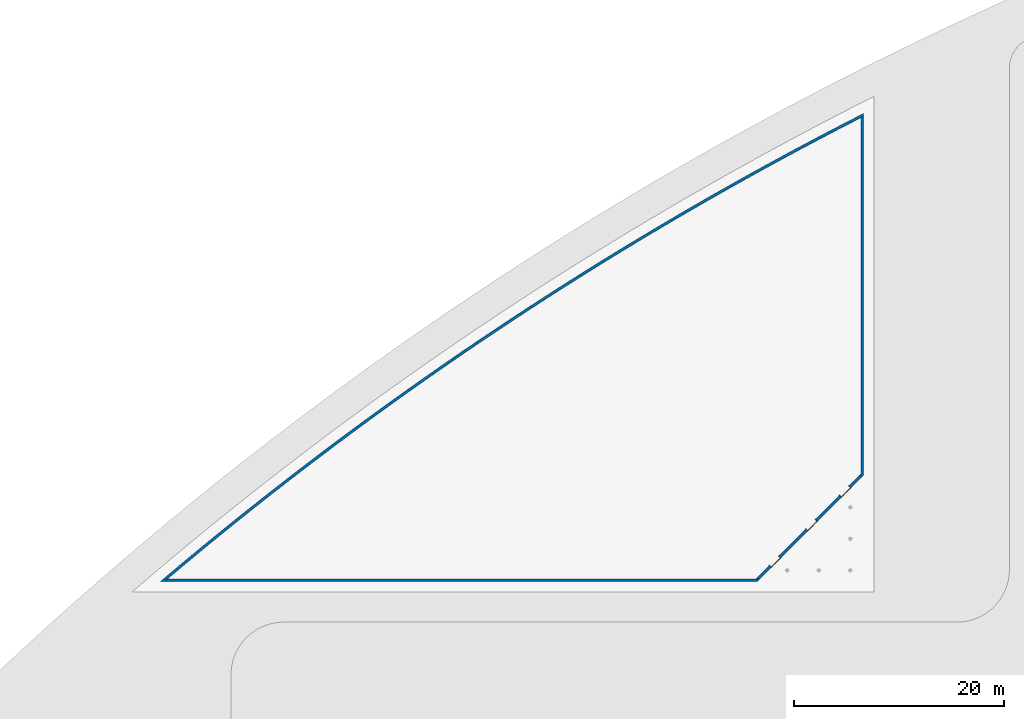
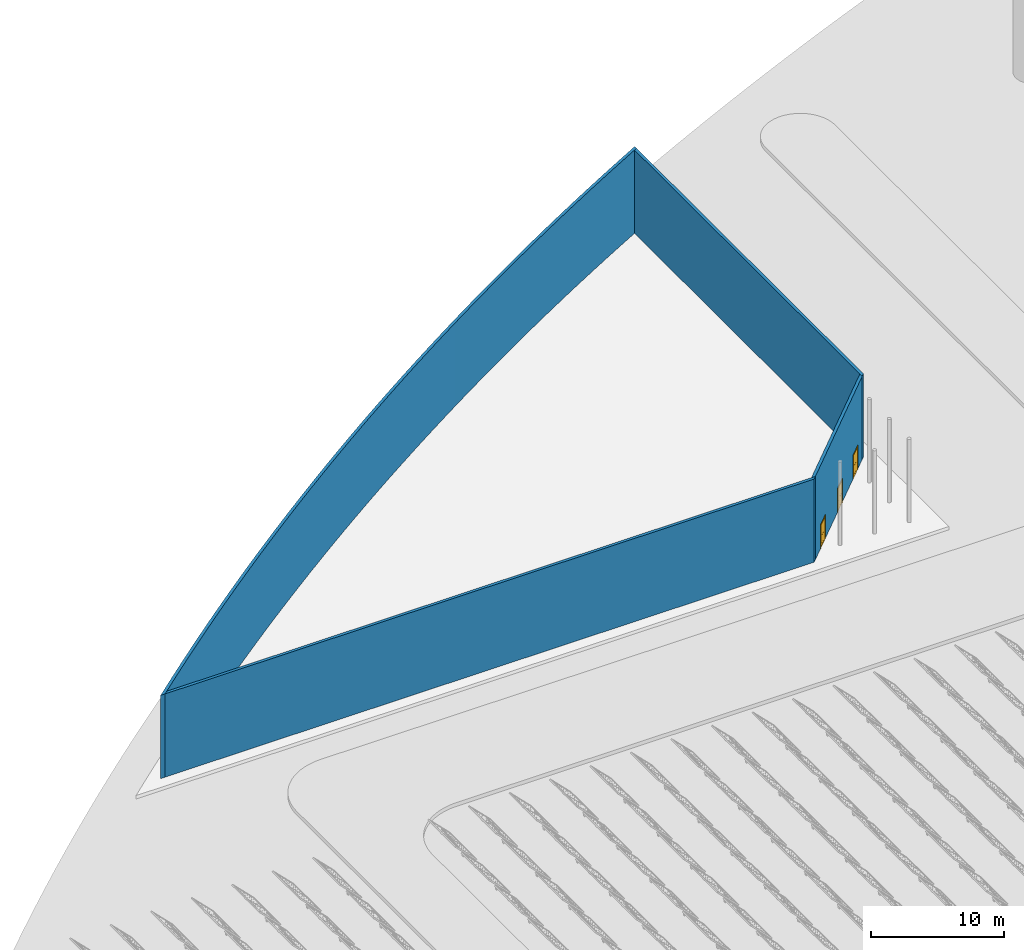
# One storey, part 12 of 39: 4 walls, 3 doors, 3 openings.
"""IFC2X3 building model written with IfcOpenShell, lengths in millimetres."""

import ifcopenshell
import ifcopenshell.guid

model = None  # the IFC model being written
_history = None  # IfcOwnerHistory: only IFC2X3 demands one
_inside = {}  # id of a spatial element -> (the spatial element, [elements in it])
_under = {}  # id of a project, library or spatial element -> (it, [spatial elements below it])
_declared = {}  # id of a project -> (the project, [libraries it declares])
_typed = {}  # id of a type object -> (the type object, [elements of that type])
_made_of = {}  # id of a material, layer set ... -> (it, [elements and type objects made of it])


def new_model(schema):
    """Start an empty IFC model of exactly this schema.

    Asked for "IFC4X3", IfcOpenShell would pick the latest addendum, in which some entities
    have other attributes; the version numbers below select the first issue.
    IFC2X3 requires an IfcOwnerHistory on every rooted entity: one is made here for all.
    """
    global model, _history
    if schema == "IFC4X3":
        model = ifcopenshell.file(schema_version=(4, 3, 0, 0))
    else:
        model = ifcopenshell.file(schema=schema)
    _inside.clear()
    _under.clear()
    _declared.clear()
    _typed.clear()
    _made_of.clear()
    _history = None
    if model.schema == "IFC2X3":
        org = make("IfcOrganization", Name="unknown")
        user = make(
            "IfcPersonAndOrganization",
            ThePerson=make("IfcPerson", FamilyName="unknown"),
            TheOrganization=org,
        )
        app = make(
            "IfcApplication",
            ApplicationDeveloper=org,
            Version="unknown",
            ApplicationFullName="unknown",
            ApplicationIdentifier="unknown",
        )
        _history = make(
            "IfcOwnerHistory",
            OwningUser=user,
            OwningApplication=app,
            ChangeAction="ADDED",
            CreationDate=0,
        )
    return model


def make(cls, **values):
    """One entity of the class cls with the attributes given. An attribute that is None is left unset."""
    return model.create_entity(
        cls, **{name: value for name, value in values.items() if value is not None}
    )


def entity(cls, *values):
    """Any entity or typed value of the class cls, its attributes in the order of the schema. None: left unset."""
    e = model.create_entity(cls)
    for i, value in enumerate(values):
        if value is not None:
            e[i] = value
    return e


def rooted(cls, **values):
    """An entity with a GlobalId (a new one), such as an element, a storey or a relation."""
    return make(cls, GlobalId=ifcopenshell.guid.new(), OwnerHistory=_history, **values)


def si_unit(unit_type, name, prefix=None):
    """IfcSIUnit, for example si_unit("LENGTHUNIT", "METRE", prefix="MILLI")."""
    return make("IfcSIUnit", UnitType=unit_type, Prefix=prefix, Name=name)


def converted_unit(unit_type, name, factor, base, dimensions=None, offset=None):
    """IfcConversionBasedUnit, such as the inch: factor (a typed value) times the base unit."""
    return make(
        "IfcConversionBasedUnit"
        if offset is None
        else "IfcConversionBasedUnitWithOffset",
        ConversionOffset=offset,
        Dimensions=None
        if dimensions is None
        else entity("IfcDimensionalExponents", *dimensions),
        UnitType=unit_type,
        Name=name,
        ConversionFactor=make(
            "IfcMeasureWithUnit", ValueComponent=factor, UnitComponent=base
        ),
    )


def derived_unit(unit_type, elements):
    """IfcDerivedUnit: a product of units, each with its exponent."""
    return make(
        "IfcDerivedUnit",
        Elements=[
            make("IfcDerivedUnitElement", Unit=unit, Exponent=power)
            for unit, power in elements
        ],
        UnitType=unit_type,
    )


def assignment(units):
    """IfcUnitAssignment: the units of a project."""
    return None if units is None else make("IfcUnitAssignment", Units=units)


def point(xyz):
    """IfcCartesianPoint."""
    return None if xyz is None else make("IfcCartesianPoint", Coordinates=xyz)


def direction(xyz):
    """IfcDirection."""
    return None if xyz is None else make("IfcDirection", DirectionRatios=xyz)


def frame(location, z_axis=None, x_axis=None):
    """IfcAxis2Placement3D, a coordinate frame: its origin and axes. An axis left out is left unset."""
    return make(
        "IfcAxis2Placement3D",
        Location=point(location),
        Axis=direction(z_axis),
        RefDirection=direction(x_axis),
    )


def frame_2d(location, x_axis=None):
    """IfcAxis2Placement2D, a coordinate frame in the plane: its origin and x axis."""
    return make(
        "IfcAxis2Placement2D", Location=point(location), RefDirection=direction(x_axis)
    )


def origin():
    """The frame at (0, 0, 0) with its axes left unset."""
    return frame((0.0, 0.0, 0.0))


def origin_2d_with_axis():
    """The frame at (0, 0) in the plane with the x axis (1, 0) written out."""
    return frame_2d((0.0, 0.0), x_axis=(1.0, 0.0))


def place(relative_to, where):
    """IfcLocalPlacement: puts the frame where relative to a parent placement (None: the world)."""
    return make(
        "IfcLocalPlacement", PlacementRelTo=relative_to, RelativePlacement=where
    )


def context(
    kind, dimensions, precision=None, world=None, true_north=None, identifier=None
):
    """IfcGeometricRepresentationContext, for example the 3D "Model" context."""
    return make(
        "IfcGeometricRepresentationContext",
        ContextIdentifier=identifier,
        ContextType=kind,
        CoordinateSpaceDimension=dimensions,
        Precision=precision,
        WorldCoordinateSystem=world,
        TrueNorth=true_north,
    )


def subcontext(parent, identifier, kind, view, scale=None):
    """IfcGeometricRepresentationSubContext, for example "Body" below "Model"."""
    return make(
        "IfcGeometricRepresentationSubContext",
        ContextIdentifier=identifier,
        ContextType=kind,
        ParentContext=parent,
        TargetScale=scale,
        TargetView=view,
    )


def project(units=None, contexts=None):
    """IfcProject with its units and contexts."""
    return rooted(
        "IfcProject",
        Name="project",
        RepresentationContexts=contexts,
        UnitsInContext=assignment(units),
    )


def spatial(cls, under=None, at=None, **own):
    """A site, building, storey or space (cls), placed at a placement, below another one or the project."""
    s = rooted(cls, ObjectPlacement=at, **own)
    if under is not None:
        _under.setdefault(under.id(), (under, []))[1].append(s)
    return s


def polyline(points):
    """IfcPolyline through the points."""
    return make("IfcPolyline", Points=[point(p) for p in points])


def circle_curve(where, radius):
    """IfcCircle in the frame where."""
    return make("IfcCircle", Position=where, Radius=radius)


def parameter(value):
    """IfcParameterValue: where a trimmed curve begins or ends, as a parameter of its basis curve."""
    return model.create_entity("IfcParameterValue", value)


def trimmed(basis, trim1, trim2, sense, master):
    """IfcTrimmedCurve: the piece of a basis curve between two trims."""
    return make(
        "IfcTrimmedCurve",
        BasisCurve=basis,
        Trim1=trim1,
        Trim2=trim2,
        SenseAgreement=sense,
        MasterRepresentation=master,
    )


def segment(curve, same_sense, transition):
    """IfcCompositeCurveSegment."""
    return make(
        "IfcCompositeCurveSegment",
        Transition=transition,
        SameSense=same_sense,
        ParentCurve=curve,
    )


def composite_curve(segments, self_intersect=None):
    """IfcCompositeCurve: segments joined end to end."""
    return make("IfcCompositeCurve", Segments=segments, SelfIntersect=self_intersect)


def profile(cls, at=None, kind="AREA", **sizes):
    """A parametric profile (cls). Its sizes go by their IFC names, for example OverallWidth=200.0."""
    return make(cls, ProfileType=kind, Position=at, **sizes)


def rectangle(**sizes):
    """IfcRectangleProfileDef."""
    return profile("IfcRectangleProfileDef", **sizes)


def outline(outer, holes=None, kind="AREA"):
    """IfcArbitraryClosedProfileDef: a profile drawn as a closed curve; with holes, ...WithVoids."""
    if holes is None:
        return make("IfcArbitraryClosedProfileDef", ProfileType=kind, OuterCurve=outer)
    return make(
        "IfcArbitraryProfileDefWithVoids",
        ProfileType=kind,
        OuterCurve=outer,
        InnerCurves=holes,
    )


def extrude(swept, where, along, depth):
    """IfcExtrudedAreaSolid: the profile swept, set in the frame where, extruded along a direction by depth."""
    return make(
        "IfcExtrudedAreaSolid",
        SweptArea=swept,
        Position=where,
        ExtrudedDirection=direction(along),
        Depth=depth,
    )


def shape(context_of_items, identifier, shape_type, items):
    """IfcShapeRepresentation: the items that make up one representation, for example the "Body"."""
    return make(
        "IfcShapeRepresentation",
        ContextOfItems=context_of_items,
        RepresentationIdentifier=identifier,
        RepresentationType=shape_type,
        Items=items,
    )


def source(mapping_origin, context_of_items, identifier, shape_type, items):
    """IfcRepresentationMap: a shape defined once, which mapped items show again and again."""
    return make(
        "IfcRepresentationMap",
        MappingOrigin=mapping_origin,
        MappedRepresentation=shape(context_of_items, identifier, shape_type, items),
    )


def transform(
    local_origin,
    x_axis=None,
    y_axis=None,
    z_axis=None,
    scale=None,
    scale2=None,
    scale3=None,
    uniform=True,
):
    """IfcCartesianTransformationOperator3D, or its non-uniform kind. x_axis, y_axis, z_axis: its Axis1, 2, 3."""
    if uniform:
        return make(
            "IfcCartesianTransformationOperator3D",
            Axis1=direction(x_axis),
            Axis2=direction(y_axis),
            LocalOrigin=point(local_origin),
            Scale=scale,
            Axis3=direction(z_axis),
        )
    return make(
        "IfcCartesianTransformationOperator3DnonUniform",
        Axis1=direction(x_axis),
        Axis2=direction(y_axis),
        LocalOrigin=point(local_origin),
        Scale=scale,
        Axis3=direction(z_axis),
        Scale2=scale2,
        Scale3=scale3,
    )


def mapped(mapping_source, mapping_target):
    """IfcMappedItem: shows the shape of a source again, moved by a transform."""
    return make(
        "IfcMappedItem", MappingSource=mapping_source, MappingTarget=mapping_target
    )


def material(Name=None, Category=None):
    """IfcMaterial."""
    return make("IfcMaterial", Name=Name, Category=Category)


def material_list(materials):
    """IfcMaterialList."""
    return make("IfcMaterialList", Materials=materials)


def layer(
    of_material, thickness, ventilated=None, Name=None, Category=None, Priority=None
):
    """IfcMaterialLayer: one layer of a wall or slab, of a material (None: an air gap)."""
    return make(
        "IfcMaterialLayer",
        Material=of_material,
        LayerThickness=thickness,
        IsVentilated=ventilated,
        Name=Name,
        Category=Category,
        Priority=Priority,
    )


def layer_set(layers, Name=None):
    """IfcMaterialLayerSet."""
    return make("IfcMaterialLayerSet", MaterialLayers=layers, LayerSetName=Name)


def layer_usage(for_layer_set, set_direction, sense, offset, extent=None):
    """IfcMaterialLayerSetUsage: how a layer set lies in its element."""
    return make(
        "IfcMaterialLayerSetUsage",
        ForLayerSet=for_layer_set,
        LayerSetDirection=set_direction,
        DirectionSense=sense,
        OffsetFromReferenceLine=offset,
        ReferenceExtent=extent,
    )


def made_of(thing, what):
    """Note that an element or type object is made of a material, layer set ...; save() writes the relation."""
    if what is not None:
        _made_of.setdefault(what.id(), (what, []))[1].append(thing)
    return thing


def type_object(cls, material=None, **own):
    """A type object (cls), such as IfcWallType, which elements share."""
    return made_of(rooted(cls, **own), material)


def type_shapes(of_type, sources):
    """Give a type object the sources (RepresentationMaps) that its elements show as mapped items."""
    of_type.RepresentationMaps = sources


def element(
    cls,
    number,
    at=None,
    inside=None,
    cuts=None,
    type_object=None,
    material=None,
    context=None,
    identifier="Body",
    shape_type=None,
    held_by="IfcProductDefinitionShape",
    body=None,
    shapes=None,
    **own,
):
    """One element of the class cls, such as IfcWall. Its Tag is "e" and its number.

    at: its placement. inside: the storey or other place that contains it. cuts: it is an
    opening in that element (IfcRelVoidsElement). A single representation is given by context,
    identifier, shape_type and body (its items); several are given by shapes. held_by: the class
    of the entity that holds the representations. save() writes the other relations.
    """
    e = rooted(cls, Tag="e%d" % number, ObjectPlacement=at, **own)
    if body is not None:
        shapes = [shape(context, identifier, shape_type, body)]
    if shapes is not None:
        e.Representation = make(held_by, Representations=shapes)
    if inside is not None:
        _inside.setdefault(inside.id(), (inside, []))[1].append(e)
    if cuts is not None:
        rooted(
            "IfcRelVoidsElement", RelatingBuildingElement=cuts, RelatedOpeningElement=e
        )
    if type_object is not None:
        _typed.setdefault(type_object.id(), (type_object, []))[1].append(e)
    return made_of(e, material)


def fill(opening, filler):
    """IfcRelFillsElement: the door or window that sits in an opening."""
    return rooted(
        "IfcRelFillsElement",
        RelatingOpeningElement=opening,
        RelatedBuildingElement=filler,
    )


def aggregate(whole, parts):
    """IfcRelAggregates: a whole, such as a stair, and the parts it consists of."""
    return rooted("IfcRelAggregates", RelatingObject=whole, RelatedObjects=parts)


def save(model, path):
    """Write the relations noted so far, then the file.

    IfcRelAggregates (storeys below a building ...), IfcRelContainedInSpatialStructure (elements
    in a storey), IfcRelDefinesByType, IfcRelAssociatesMaterial and IfcRelDeclares: one each for
    every whole, place, type object, material and project.
    """
    for whole, parts in _under.values():
        aggregate(whole, parts)
    for where, things in _inside.values():
        rooted(
            "IfcRelContainedInSpatialStructure",
            RelatedElements=things,
            RelatingStructure=where,
        )
    for kind, things in _typed.values():
        rooted("IfcRelDefinesByType", RelatedObjects=things, RelatingType=kind)
    for what, things in _made_of.values():
        rooted("IfcRelAssociatesMaterial", RelatedObjects=things, RelatingMaterial=what)
    for by, libraries in _declared.values():
        rooted("IfcRelDeclares", RelatingContext=by, RelatedDefinitions=libraries)
    model.write(path)


model = new_model("IFC2X3")

# Units and contexts
model_context = context("Model", 3, precision=1e-06, world=origin(), true_north=direction((2.0, 6.12303176911189e-17, 1.0)))
context_of_model = context(None, 3, precision=1e-06, world=origin(), true_north=direction((2.0, 6.12303176911189e-17, 1.0)))
body_context = subcontext(model_context, "Body", "Model", "MODEL_VIEW")
ifc_project = project(units=[si_unit("LENGTHUNIT", "METRE", prefix="MILLI"), si_unit("AREAUNIT", "SQUARE_METRE", prefix="MILLI"), si_unit("VOLUMEUNIT", "CUBIC_METRE", prefix="MILLI"), converted_unit("PLANEANGLEUNIT", "DEGREE", entity("IfcRatioMeasure", 0.0174532925199433), si_unit("PLANEANGLEUNIT", "RADIAN"), dimensions=[0, 0, 0, 0, 0, 0, 0]), si_unit("MASSUNIT", "GRAM", prefix="KILO"), si_unit("TIMEUNIT", "SECOND"), si_unit("THERMODYNAMICTEMPERATUREUNIT", "KELVIN"), derived_unit("THERMALTRANSMITTANCEUNIT", [(si_unit("MASSUNIT", "GRAM", prefix="KILO"), 1), (si_unit("THERMODYNAMICTEMPERATUREUNIT", "KELVIN"), -1), (si_unit("TIMEUNIT", "SECOND"), -3)]), derived_unit("VOLUMETRICFLOWRATEUNIT", [(si_unit("LENGTHUNIT", "METRE"), 3), (si_unit("TIMEUNIT", "SECOND"), -1)])], contexts=[model_context, context_of_model])

# Site, building, storey
site_placement = place(None, origin())
site = spatial("IfcSite", under=ifc_project, at=site_placement, CompositionType="ELEMENT")
building_placement = place(site_placement, origin())
building = spatial("IfcBuilding", under=site, at=building_placement, CompositionType="ELEMENT")
storey_placement = place(building_placement, frame((0.0, 0.0, 4000.0)))
storey = spatial("IfcBuildingStorey", under=building, at=storey_placement, Name="Level 2", CompositionType="ELEMENT", Elevation=4000.0)

# Walls
ifc_material_1 = material(Name="Concrete - Cast In Situ")
ifc_layer = layer(ifc_material_1, 250.0)
ifc_layer_set = layer_set([ifc_layer], Name="Basic Wall:Structure wall")
ifc_layer_usage_1 = layer_usage(ifc_layer_set, "AXIS2", "NEGATIVE", 125.0)
wall_type = type_object("IfcWallType", Name="Basic Wall:Structure wall", PredefinedType="STANDARD", material=ifc_layer_set)
wall_1_placement = place(storey_placement, frame((-48572.789510168, 749323.234232794, 362.0)))
element("IfcWallStandardCase", 1, at=wall_1_placement, inside=storey, type_object=wall_type, material=ifc_layer_usage_1, Name="Basic Wall:Structure wall", ObjectType="Basic Wall:Structure wall", context=body_context, shape_type="SweptSolid", body=[
    extrude(outline(composite_curve([segment(polyline([(-66494.906786765, -44367.4549151187), (-66347.1667188782, -44242.4129308178)]), True, "CONTINUOUS"), segment(polyline([(-66347.1667188782, -44242.4129308178), (-66199.3556370885, -44117.452787742)]), True, "CONTINUOUS"), segment(polyline([(-66199.3556370885, -44117.452787742), (-64642.2102802385, -42809.609588203)]), True, "CONTINUOUS"), segment(polyline([(-64642.2102802385, -42809.609588203), (-63077.3981088071, -41510.943304229)]), True, "CONTINUOUS"), segment(polyline([(-63077.3981088071, -41510.943304229), (-61504.9762005664, -40221.5013346742)]), True, "CONTINUOUS"), segment(polyline([(-61504.9762005664, -40221.5013346742), (-59924.9989307479, -38941.3282691697)]), True, "CONTINUOUS"), segment(polyline([(-59924.9989307479, -38941.3282691697), (-58337.5209356515, -37670.4683766581)]), True, "CONTINUOUS"), segment(polyline([(-58337.5209356515, -37670.4683766581), (-56742.5971109655, -36408.965604038)]), True, "CONTINUOUS"), segment(polyline([(-56742.5971109655, -36408.965604038), (-55140.2826098583, -35156.863574634)]), True, "CONTINUOUS"), segment(polyline([(-55140.2826098583, -35156.863574634), (-53530.6328410722, -33914.20558669)]), True, "CONTINUOUS"), segment(polyline([(-53530.6328410722, -33914.20558669), (-51913.7034670048, -32681.03461187)]), True, "CONTINUOUS"), segment(polyline([(-51913.7034670048, -32681.03461187), (-50289.5504017858, -31457.3932937736)]), True, "CONTINUOUS"), segment(polyline([(-50289.5504017858, -31457.3932937736), (-48658.2298093435, -30243.3239464603)]), True, "CONTINUOUS"), segment(polyline([(-48658.2298093435, -30243.3239464603), (-47019.7981014625, -29038.8685529876)]), True, "CONTINUOUS"), segment(polyline([(-47019.7981014625, -29038.8685529876), (-45374.311935833, -27844.068763958)]), True, "CONTINUOUS"), segment(polyline([(-45374.311935833, -27844.068763958), (-43721.8282140906, -26658.9658960789)]), True, "CONTINUOUS"), segment(polyline([(-43721.8282140906, -26658.9658960789), (-42062.4040798497, -25483.6009307342)]), True, "CONTINUOUS"), segment(polyline([(-42062.4040798497, -25483.6009307342), (-40396.0969167279, -24318.0145125675)]), True, "CONTINUOUS"), segment(polyline([(-40396.0969167279, -24318.0145125675), (-38722.9643463596, -23162.2469480754)]), True, "CONTINUOUS"), segment(polyline([(-38722.9643463596, -23162.2469480754), (-37043.064226406, -22016.3382042147)]), True, "CONTINUOUS"), segment(polyline([(-37043.064226406, -22016.3382042147), (-35356.4546485519, -20880.32790702)]), True, "CONTINUOUS"), segment(polyline([(-35356.4546485519, -20880.32790702), (-33663.1939364993, -19754.2553402335)]), True, "CONTINUOUS"), segment(polyline([(-33663.1939364993, -19754.2553402335), (-31963.3406439478, -18638.1594439462)]), True, "CONTINUOUS"), segment(polyline([(-31963.3406439478, -18638.1594439462), (-30256.9535525729, -17532.0788132524)]), True, "CONTINUOUS"), segment(polyline([(-30256.9535525729, -17532.0788132524), (-28544.0916699908, -16436.0516969136)]), True, "CONTINUOUS"), segment(polyline([(-28544.0916699908, -16436.0516969136), (-26824.8142277184, -15350.1159960363)]), True, "CONTINUOUS"), segment(polyline([(-26824.8142277184, -15350.1159960363), (-25099.1806791262, -14274.3092627621)]), True, "CONTINUOUS"), segment(polyline([(-25099.1806791262, -14274.3092627621), (-23367.2506973813, -13208.6686989687)]), True, "CONTINUOUS"), segment(polyline([(-23367.2506973813, -13208.6686989687), (-21629.0841733846, -12153.2311549831)]), True, "CONTINUOUS"), segment(polyline([(-21629.0841733846, -12153.2311549831), (-19884.7412136983, -11108.0331283074)]), True, "CONTINUOUS"), segment(polyline([(-19884.7412136983, -11108.0331283074), (-18134.2821384692, -10073.1107623574)]), True, "CONTINUOUS"), segment(polyline([(-18134.2821384692, -10073.1107623574), (-16377.7674793421, -9048.49984521157)]), True, "CONTINUOUS"), segment(polyline([(-16377.7674793421, -9048.49984521157), (-14615.2579773662, -8034.2358083748)]), True, "CONTINUOUS"), segment(polyline([(-14615.2579773662, -8034.2358083748), (-12846.8145808953, -7030.35372555218)]), True, "CONTINUOUS"), segment(polyline([(-12846.8145808953, -7030.35372555218), (-11072.4984434794, -6036.88831143607)]), True, "CONTINUOUS"), segment(polyline([(-11072.4984434794, -6036.88831143607), (-9292.37092175103, -5053.87392050709)]), True, "CONTINUOUS"), segment(polyline([(-9292.37092175103, -5053.87392050709), (-7506.49357330258, -4081.34454584395)]), True, "CONTINUOUS"), segment(polyline([(-7506.49357330258, -4081.34454584395), (-5714.92815455786, -3119.33381794942)]), True, "CONTINUOUS"), segment(polyline([(-5714.92815455786, -3119.33381794942), (-3917.73661856104, -2167.8750035472)]), True, "CONTINUOUS"), segment(polyline([(-3917.73661856104, -2167.8750035472), (-2114.98111756835, -1227.00100688837)]), True, "CONTINUOUS"), segment(polyline([(-2114.98111756835, -1227.00100688837), (-306.726788668387, -296.745803656024)]), True, "CONTINUOUS"), segment(polyline([(-306.726788668387, -296.745803656024), (-181.738037474534, -232.941447108197)]), True, "CONTINUOUS"), segment(polyline([(-181.738037474534, -232.941447108197), (-56.7244375210319, -169.188356186455)]), True, "CONTINUOUS"), segment(polyline([(-56.7244375188835, -169.188356185346), (-56.7244375190914, 111.388231820703)]), True, "CONTINUOUS"), segment(trimmed(circle_curve(frame_2d((156981.542085549, -308260.375354556), x_axis=(1.0, 0.0)), 346055.1426145), [parameter(116.987461336965)], [parameter(130.308287354336)], True, "PARAMETER"), True, "CONTINUOUS"), segment(polyline([(-66881.5595455262, -44367.4549151147), (-66494.9067867603, -44367.4549151147)]), True, "CONTINUOUS")], self_intersect=False)), origin(), (0.0, 0.0, 1.0), 7638.0),
])
ifc_layer_usage_2 = layer_usage(ifc_layer_set, "AXIS2", "NEGATIVE", 125.0)
wall_2_placement = place(storey_placement, frame((-48754.5139476852, 714804.002622383, 362.0), z_axis=(0.0, 0.0, 1.0), x_axis=(0.0, 1.0, 0.0)))
element("IfcWallStandardCase", 2, at=wall_2_placement, inside=storey, type_object=wall_type, material=ifc_layer_usage_2, Name="Basic Wall:Structure wall", ObjectType="Basic Wall:Structure wall", context=body_context, shape_type="SweptSolid", body=[
    extrude(outline(composite_curve([segment(trimmed(circle_curve(frame_2d((-273741.143744144, -157163.266523067), x_axis=(0.0, -1.0)), 345805.1426145), [parameter(117.008557467758)], [parameter(117.055059641523)], True, "PARAMETER"), True, "CONTINUOUS"), segment(polyline([(34222.4870189767, 125.0), (353.553390593269, 125.0)]), True, "CONTINUOUS"), segment(polyline([(353.553390593269, 125.0), (0.0, 125.0)]), True, "CONTINUOUS"), segment(polyline([(0.0, 125.0), (250.0, -125.0)]), True, "CONTINUOUS"), segment(polyline([(250.0, -125.0), (34350.0432542271, -125.0)]), True, "CONTINUOUS")], self_intersect=False)), origin(), (0.0, 0.0, 1.0), 7638.0),
])
ifc_layer_usage_3 = layer_usage(ifc_layer_set, "AXIS2", "NEGATIVE", 125.0)
wall_3_placement = place(storey_placement, frame((-115067.696296928, 705080.779317679, 362.0)))
element("IfcWallStandardCase", 3, at=wall_3_placement, inside=storey, type_object=wall_type, material=ifc_layer_usage_3, Name="Basic Wall:Structure wall", ObjectType="Basic Wall:Structure wall", context=body_context, shape_type="SweptSolid", body=[
    extrude(outline(composite_curve([segment(polyline([(56339.9590445396, -125.0), (56589.9590445396, 125.0)]), True, "CONTINUOUS"), segment(polyline([(56589.9590445396, 125.0), (56236.4056539463, 125.0)]), True, "CONTINUOUS"), segment(polyline([(56236.4056539463, 125.0), (295.548613442678, 125.0)]), True, "CONTINUOUS"), segment(trimmed(circle_curve(frame_2d((223476.448872309, -264017.92043944), x_axis=(1.0, 0.0)), 345805.1426145), [parameter(130.195295557796)], [parameter(130.259433955655)], True, "PARAMETER"), True, "CONTINUOUS"), segment(polyline([(0.0, -125.0), (56339.9590445396, -125.0)]), True, "CONTINUOUS")], self_intersect=False)), origin(), (0.0, 0.0, 1.0), 7638.0),
])

# Wall, openings, doors
ifc_layer_usage_4 = layer_usage(ifc_layer_set, "AXIS2", "NEGATIVE", 125.0)
wall_4_placement = place(storey_placement, frame((-48791.1256000369, 715069.167665328, 362.0), z_axis=(0.0, 0.0, 1.0), x_axis=(-0.707106781186548, -0.707106781186547, 0.0)))
wall_4 = element("IfcWallStandardCase", 4, at=wall_4_placement, inside=storey, type_object=wall_type, material=ifc_layer_usage_4, Name="Basic Wall:Structure wall", ObjectType="Basic Wall:Structure wall", context=body_context, shape_type="SweptSolid", body=[
    extrude(outline(polyline([(0.0, -125.0), (14073.9375721971, -125.0), (13823.937572197, 125.0), (250.0, 125.0), (0.0, -125.0)])), origin(), (0.0, 0.0, 1.0), 7638.0),
])
opening_1_placement = place(wall_4_placement, frame((6132.59105794845, -125.0, 0.0)))
opening_1 = element("IfcOpeningElement", 5, at=opening_1_placement, cuts=wall_4, Name="M_Bifold-4 Panel:1220 x 2134mm:1220 x 2134mm:1", ObjectType="Opening", context=body_context, shape_type="SweptSolid", body=[
    extrude(rectangle(XDim=2134.0, YDim=1220.0, at=frame_2d((1067.0, 610.0), x_axis=(1.0, 0.0))), frame((0.0, 0.0, 0.0), z_axis=(0.0, 1.0, 0.0), x_axis=(0.0, 0.0, 1.0)), (0.0, 0.0, 1.0), 250.0),
])
opening_2_placement = place(wall_4_placement, frame((1612.5910579485, -125.0, 0.0)))
opening_2 = element("IfcOpeningElement", 6, at=opening_2_placement, cuts=wall_4, Name="M_Bifold-4 Panel:1220 x 2134mm:1220 x 2134mm:1", ObjectType="Opening", context=body_context, shape_type="SweptSolid", body=[
    extrude(rectangle(XDim=2134.0, YDim=1220.0, at=frame_2d((1067.0, 610.0), x_axis=(1.0, 0.0))), frame((0.0, 0.0, 0.0), z_axis=(0.0, 1.0, 0.0), x_axis=(0.0, 0.0, 1.0)), (0.0, 0.0, 1.0), 250.0),
])
opening_3_placement = place(wall_4_placement, frame((11052.5910579484, -125.0, 0.0)))
opening_3 = element("IfcOpeningElement", 7, at=opening_3_placement, cuts=wall_4, Name="M_Bifold-4 Panel:1220 x 2134mm:1220 x 2134mm:1", ObjectType="Opening", context=body_context, shape_type="SweptSolid", body=[
    extrude(rectangle(XDim=2134.0, YDim=1220.0, at=frame_2d((1067.0, 610.0), x_axis=(1.0, 0.0))), frame((0.0, 0.0, 0.0), z_axis=(0.0, 1.0, 0.0), x_axis=(0.0, 0.0, 1.0)), (0.0, 0.0, 1.0), 250.0),
])
ifc_material_2 = material(Name="Door - Panel")
ifc_material_3 = material(Name="Door - Frame")
ifc_material_list_1 = material_list([ifc_material_2, ifc_material_3])
ifc_material_list_2 = material_list([ifc_material_2, ifc_material_3])
door_style = type_object("IfcDoorStyle", Name="1220 x 2134mm", ConstructionType="NOTDEFINED", OperationType="NOTDEFINED", ParameterTakesPrecedence=False, Sizeable=False, material=ifc_material_list_2)
shared_shape = source(origin(), body_context, "Body", "SweptSolid", [
    extrude(rectangle(XDim=12.7000000000036, YDim=127.199999999996, at=frame_2d((0.0, 3.5527136788005e-14), x_axis=(1.0, 0.0))), frame((152.499999999964, 230.950000000008, 965.200000000053), z_axis=(0.0, 0.0, 1.0), x_axis=(0.0, -1.0, 0.0)), (0.0, 0.0, 1.0), 1086.25000000008),
    extrude(rectangle(XDim=12.7000000000036, YDim=127.199999999999, at=frame_2d((0.0, -3.5527136788005e-14), x_axis=(1.0, 0.0))), frame((1067.49999999997, 230.950000000005, 965.199999999998), z_axis=(0.0, 0.0, 1.0), x_axis=(0.0, -1.0, 0.0)), (0.0, 0.0, 1.0), 1086.25000000006),
    extrude(rectangle(XDim=12.7000000000036, YDim=127.199999999999, at=origin_2d_with_axis()), frame((1067.49999999995, 230.950000000005, 184.149999999999), z_axis=(0.0, 0.0, 1.0), x_axis=(0.0, -1.0, 0.0)), (0.0, 0.0, 1.0), 565.149999999999),
    extrude(rectangle(XDim=12.7000000000036, YDim=127.199999999974, at=frame_2d((8.43769498715119e-15, 0.0), x_axis=(1.0, 0.0))), frame((762.499999999977, 230.950000000006, 965.199999999998), z_axis=(0.0, 0.0, 1.0), x_axis=(0.0, -1.0, 0.0)), (0.0, 0.0, 1.0), 1086.25000000006),
    extrude(rectangle(XDim=12.7000000000036, YDim=127.199999999943, at=frame_2d((8.43769498715119e-15, 0.0), x_axis=(1.0, 0.0))), frame((762.499999999947, 230.950000000006, 184.149999999997), z_axis=(0.0, 0.0, 1.0), x_axis=(0.0, -1.0, 0.0)), (0.0, 0.0, 1.0), 565.15),
    extrude(rectangle(XDim=12.7000000000036, YDim=127.200000000015, at=frame_2d((-8.43769498715119e-15, 0.0), x_axis=(1.0, 0.0))), frame((457.499999999947, 230.950000000007, 184.150000000029), z_axis=(0.0, 0.0, 1.0), x_axis=(0.0, -1.0, 0.0)), (0.0, 0.0, 1.0), 565.14999999999),
    extrude(rectangle(XDim=12.7000000000036, YDim=127.200000000036, at=frame_2d((-8.43769498715119e-15, 0.0), x_axis=(1.0, 0.0))), frame((457.499999999977, 230.950000000007, 965.20000000002), z_axis=(0.0, 0.0, 1.0), x_axis=(0.0, -1.0, 0.0)), (0.0, 0.0, 1.0), 1086.25000000008),
    extrude(rectangle(XDim=12.7000000000036, YDim=127.200000000006, at=frame_2d((0.0, 3.19744231092045e-14), x_axis=(1.0, 0.0))), frame((152.499999999925, 230.950000000008, 184.150000000052), z_axis=(0.0, 0.0, 1.0), x_axis=(0.0, -1.0, 0.0)), (0.0, 0.0, 1.0), 565.150000000021),
    extrude(outline(polyline([(-686.0, -1086.0), (-610.0, -1086.0), (-610.0, 1048.0), (610.0, 1048.0), (610.0, -1086.0), (686.0, -1086.0), (686.0, 1124.0), (-686.0, 1124.0), (-686.0, -1086.0)])), frame((610.0, -25.3999999999962, 1086.0), z_axis=(0.0, 1.0, 0.0), x_axis=(-1.0, 0.0, 0.0)), (0.0, 0.0, 1.0), 25.3999999999942),
    extrude(outline(polyline([(-686.0, -1086.0), (-610.0, -1086.0), (-610.0, 1048.0), (610.0, 1048.0), (610.0, -1086.0), (686.0, -1086.0), (686.0, 1124.0), (-686.0, 1124.0), (-686.0, -1086.0)])), frame((610.0, 250.0, 1086.0), z_axis=(0.0, 1.0, 0.0), x_axis=(-1.0, 0.0, 0.0)), (0.0, 0.0, 1.0), 25.4000000000063),
    extrude(outline(polyline([(-1067.0, -152.5), (1067.0, -152.5), (1067.0, 152.5), (-1067.0, 152.5), (-1067.0, -152.5)]), holes=[polyline([(984.450000000135, -63.6000000000341), (-101.799999999947, -63.6000000000341), (-101.799999999947, 63.5999999999598), (984.450000000135, 63.5999999999598), (984.450000000135, -63.6000000000341)]), polyline([(-317.699999999927, -63.6000000000592), (-882.849999999949, -63.6000000000592), (-882.849999999949, 63.5999999999276), (-317.699999999927, 63.5999999999276), (-317.699999999927, -63.6000000000592)])]), frame((152.5, 211.899999999999, 1067.0), z_axis=(0.0, 1.0, 0.0), x_axis=(0.0, 0.0, 1.0)), (0.0, 0.0, 1.0), 38.1000000000007),
    extrude(outline(polyline([(-1067.0, -152.5), (1067.0, -152.5), (1067.0, 152.5), (-1067.0, 152.5), (-1067.0, -152.5)]), holes=[polyline([(984.4500000001, -63.6000000000357), (-101.799999999979, -63.6000000000357), (-101.799999999979, 63.5999999999947), (984.4500000001, 63.5999999999947), (984.4500000001, -63.6000000000357)]), polyline([(-317.699999999965, -63.6000000000611), (-882.849999999987, -63.6000000000611), (-882.849999999987, 63.5999999999543), (-317.699999999965, 63.5999999999543), (-317.699999999965, -63.6000000000611)])]), frame((457.5, 211.899999999998, 1067.0), z_axis=(0.0, 1.0, 0.0), x_axis=(0.0, 0.0, 1.0)), (0.0, 0.0, 1.0), 38.1000000000007),
    extrude(outline(polyline([(-1067.0, -152.500000000003), (1067.0, -152.500000000003), (1067.0, 152.500000000003), (-1067.0, 152.500000000003), (-1067.0, -152.500000000003)]), holes=[polyline([(984.450000000061, -63.6000000000024), (-101.800000000002, -63.6000000000024), (-101.800000000002, 63.5999999999556), (984.450000000061, 63.5999999999556), (984.450000000061, -63.6000000000024)]), polyline([(-317.700000000002, -63.6000000000252), (-882.850000000002, -63.6000000000252), (-882.850000000002, 63.5999999999169), (-317.700000000002, 63.5999999999169), (-317.700000000002, -63.6000000000252)])]), frame((762.500000000002, 211.899999999997, 1067.0), z_axis=(0.0, 1.0, 0.0), x_axis=(0.0, 0.0, 1.0)), (0.0, 0.0, 1.0), 38.1000000000007),
    extrude(outline(polyline([(-1067.0, -152.5), (1067.0, -152.5), (1067.0, 152.5), (-1067.0, 152.5), (-1067.0, -152.5)]), holes=[polyline([(984.45000000006, -63.600000000039), (-101.800000000001, -63.600000000039), (-101.800000000001, 63.5999999999594), (984.45000000006, 63.5999999999594), (984.45000000006, -63.600000000039)]), polyline([(-317.700000000001, -63.6000000000574), (-882.850000000001, -63.6000000000574), (-882.850000000001, 63.5999999999416), (-317.700000000001, 63.5999999999416), (-317.700000000001, -63.6000000000574)])]), frame((1067.50000000001, 211.899999999996, 1067.0), z_axis=(0.0, 1.0, 0.0), x_axis=(0.0, 0.0, 1.0)), (0.0, 0.0, 1.0), 38.1000000000007),
])
type_shapes(door_style, [shared_shape])
door_1_placement = place(opening_1_placement, origin())
door_1 = element("IfcDoor", 8, at=door_1_placement, inside=storey, type_object=door_style, material=ifc_material_list_1, Name="M_Bifold-4 Panel:1220 x 2134mm", ObjectType="1220 x 2134mm", OverallHeight=2134.0, OverallWidth=1220.00000000005, context=body_context, shape_type="MappedRepresentation", body=[
    mapped(shared_shape, transform((0.0, 0.0, 0.0), scale=1.0)),
])
fill(opening_1, door_1)
ifc_material_list_3 = material_list([ifc_material_2, ifc_material_3])
door_2_placement = place(opening_2_placement, origin())
door_2 = element("IfcDoor", 9, at=door_2_placement, inside=storey, type_object=door_style, material=ifc_material_list_3, Name="M_Bifold-4 Panel:1220 x 2134mm", ObjectType="1220 x 2134mm", OverallHeight=2134.0, OverallWidth=1220.00000000005, context=body_context, shape_type="MappedRepresentation", body=[
    mapped(shared_shape, transform((0.0, 0.0, 0.0), scale=1.0)),
])
fill(opening_2, door_2)
ifc_material_list_4 = material_list([ifc_material_2, ifc_material_3])
door_3_placement = place(opening_3_placement, origin())
door_3 = element("IfcDoor", 10, at=door_3_placement, inside=storey, type_object=door_style, material=ifc_material_list_4, Name="M_Bifold-4 Panel:1220 x 2134mm", ObjectType="1220 x 2134mm", OverallHeight=2134.0, OverallWidth=1220.00000000005, context=body_context, shape_type="MappedRepresentation", body=[
    mapped(shared_shape, transform((0.0, 0.0, 0.0), scale=1.0)),
])
fill(opening_3, door_3)

save(model, "model.ifc")
